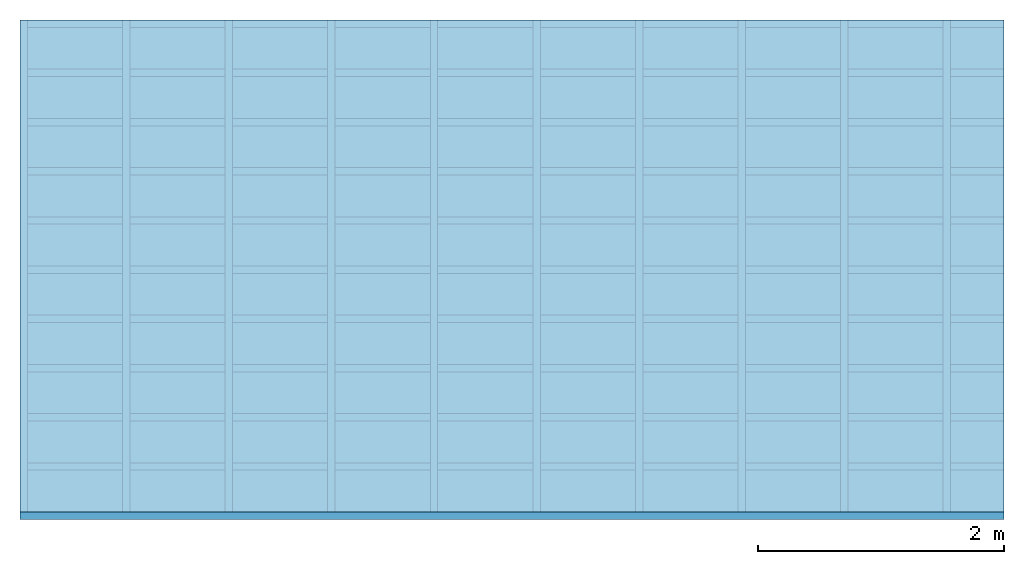
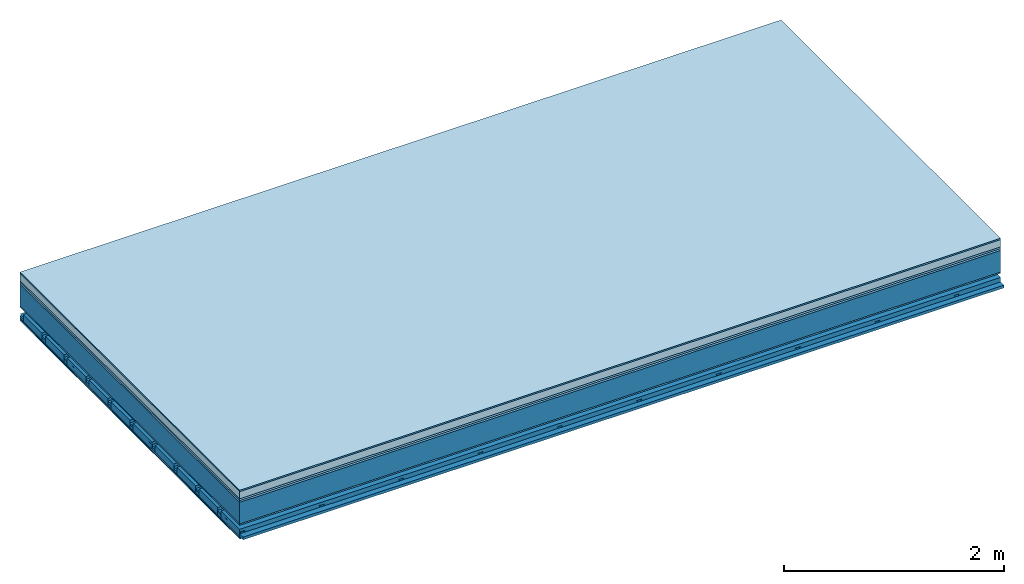
# One storey: 8 plates, 4 members, 1 element without a shape of its own.
"""IFC4 building model written with IfcOpenShell, lengths in metres."""

import ifcopenshell
import ifcopenshell.guid

model = None  # the IFC model being written
_history = None  # IfcOwnerHistory: only IFC2X3 demands one
_inside = {}  # id of a spatial element -> (the spatial element, [elements in it])
_under = {}  # id of a project, library or spatial element -> (it, [spatial elements below it])
_declared = {}  # id of a project -> (the project, [libraries it declares])
_typed = {}  # id of a type object -> (the type object, [elements of that type])
_made_of = {}  # id of a material, layer set ... -> (it, [elements and type objects made of it])


def new_model(schema):
    """Start an empty IFC model of exactly this schema.

    Asked for "IFC4X3", IfcOpenShell would pick the latest addendum, in which some entities
    have other attributes; the version numbers below select the first issue.
    IFC2X3 requires an IfcOwnerHistory on every rooted entity: one is made here for all.
    """
    global model, _history
    if schema == "IFC4X3":
        model = ifcopenshell.file(schema_version=(4, 3, 0, 0))
    else:
        model = ifcopenshell.file(schema=schema)
    _inside.clear()
    _under.clear()
    _declared.clear()
    _typed.clear()
    _made_of.clear()
    _history = None
    if model.schema == "IFC2X3":
        org = make("IfcOrganization", Name="unknown")
        user = make(
            "IfcPersonAndOrganization",
            ThePerson=make("IfcPerson", FamilyName="unknown"),
            TheOrganization=org,
        )
        app = make(
            "IfcApplication",
            ApplicationDeveloper=org,
            Version="unknown",
            ApplicationFullName="unknown",
            ApplicationIdentifier="unknown",
        )
        _history = make(
            "IfcOwnerHistory",
            OwningUser=user,
            OwningApplication=app,
            ChangeAction="ADDED",
            CreationDate=0,
        )
    return model


def make(cls, **values):
    """One entity of the class cls with the attributes given. An attribute that is None is left unset."""
    return model.create_entity(
        cls, **{name: value for name, value in values.items() if value is not None}
    )


def rooted(cls, **values):
    """An entity with a GlobalId (a new one), such as an element, a storey or a relation."""
    return make(cls, GlobalId=ifcopenshell.guid.new(), OwnerHistory=_history, **values)


def si_unit(unit_type, name, prefix=None):
    """IfcSIUnit, for example si_unit("LENGTHUNIT", "METRE", prefix="MILLI")."""
    return make("IfcSIUnit", UnitType=unit_type, Prefix=prefix, Name=name)


def derived_unit(unit_type, elements):
    """IfcDerivedUnit: a product of units, each with its exponent."""
    return make(
        "IfcDerivedUnit",
        Elements=[
            make("IfcDerivedUnitElement", Unit=unit, Exponent=power)
            for unit, power in elements
        ],
        UnitType=unit_type,
    )


def assignment(units):
    """IfcUnitAssignment: the units of a project."""
    return None if units is None else make("IfcUnitAssignment", Units=units)


def point(xyz):
    """IfcCartesianPoint."""
    return None if xyz is None else make("IfcCartesianPoint", Coordinates=xyz)


def direction(xyz):
    """IfcDirection."""
    return None if xyz is None else make("IfcDirection", DirectionRatios=xyz)


def frame(location, z_axis=None, x_axis=None):
    """IfcAxis2Placement3D, a coordinate frame: its origin and axes. An axis left out is left unset."""
    return make(
        "IfcAxis2Placement3D",
        Location=point(location),
        Axis=direction(z_axis),
        RefDirection=direction(x_axis),
    )


def frame_2d(location, x_axis=None):
    """IfcAxis2Placement2D, a coordinate frame in the plane: its origin and x axis."""
    return make(
        "IfcAxis2Placement2D", Location=point(location), RefDirection=direction(x_axis)
    )


def origin():
    """The frame at (0, 0, 0) with its axes left unset."""
    return frame((0.0, 0.0, 0.0))


def origin_with_axes():
    """The frame at (0, 0, 0) with the z axis (0, 0, 1) and the x axis (1, 0, 0) written out."""
    return frame((0.0, 0.0, 0.0), z_axis=(0.0, 0.0, 1.0), x_axis=(1.0, 0.0, 0.0))


def place(relative_to, where):
    """IfcLocalPlacement: puts the frame where relative to a parent placement (None: the world)."""
    return make(
        "IfcLocalPlacement", PlacementRelTo=relative_to, RelativePlacement=where
    )


def context(
    kind, dimensions, precision=None, world=None, true_north=None, identifier=None
):
    """IfcGeometricRepresentationContext, for example the 3D "Model" context."""
    return make(
        "IfcGeometricRepresentationContext",
        ContextIdentifier=identifier,
        ContextType=kind,
        CoordinateSpaceDimension=dimensions,
        Precision=precision,
        WorldCoordinateSystem=world,
        TrueNorth=true_north,
    )


def project(units=None, contexts=None):
    """IfcProject with its units and contexts."""
    return rooted(
        "IfcProject",
        Name="project",
        RepresentationContexts=contexts,
        UnitsInContext=assignment(units),
    )


def spatial(cls, under=None, at=None, **own):
    """A site, building, storey or space (cls), placed at a placement, below another one or the project."""
    s = rooted(cls, ObjectPlacement=at, **own)
    if under is not None:
        _under.setdefault(under.id(), (under, []))[1].append(s)
    return s


def polyline(points):
    """IfcPolyline through the points."""
    return make("IfcPolyline", Points=[point(p) for p in points])


def profile(cls, at=None, kind="AREA", **sizes):
    """A parametric profile (cls). Its sizes go by their IFC names, for example OverallWidth=200.0."""
    return make(cls, ProfileType=kind, Position=at, **sizes)


def rectangle(**sizes):
    """IfcRectangleProfileDef."""
    return profile("IfcRectangleProfileDef", **sizes)


def outline(outer, holes=None, kind="AREA"):
    """IfcArbitraryClosedProfileDef: a profile drawn as a closed curve; with holes, ...WithVoids."""
    if holes is None:
        return make("IfcArbitraryClosedProfileDef", ProfileType=kind, OuterCurve=outer)
    return make(
        "IfcArbitraryProfileDefWithVoids",
        ProfileType=kind,
        OuterCurve=outer,
        InnerCurves=holes,
    )


def extrude(swept, where, along, depth):
    """IfcExtrudedAreaSolid: the profile swept, set in the frame where, extruded along a direction by depth."""
    return make(
        "IfcExtrudedAreaSolid",
        SweptArea=swept,
        Position=where,
        ExtrudedDirection=direction(along),
        Depth=depth,
    )


def shape(context_of_items, identifier, shape_type, items):
    """IfcShapeRepresentation: the items that make up one representation, for example the "Body"."""
    return make(
        "IfcShapeRepresentation",
        ContextOfItems=context_of_items,
        RepresentationIdentifier=identifier,
        RepresentationType=shape_type,
        Items=items,
    )


def material(Name=None, Category=None):
    """IfcMaterial."""
    return make("IfcMaterial", Name=Name, Category=Category)


def layer(
    of_material, thickness, ventilated=None, Name=None, Category=None, Priority=None
):
    """IfcMaterialLayer: one layer of a wall or slab, of a material (None: an air gap)."""
    return make(
        "IfcMaterialLayer",
        Material=of_material,
        LayerThickness=thickness,
        IsVentilated=ventilated,
        Name=Name,
        Category=Category,
        Priority=Priority,
    )


def layer_set(layers, Name=None):
    """IfcMaterialLayerSet."""
    return make("IfcMaterialLayerSet", MaterialLayers=layers, LayerSetName=Name)


def made_of(thing, what):
    """Note that an element or type object is made of a material, layer set ...; save() writes the relation."""
    if what is not None:
        _made_of.setdefault(what.id(), (what, []))[1].append(thing)
    return thing


def type_object(cls, material=None, **own):
    """A type object (cls), such as IfcWallType, which elements share."""
    return made_of(rooted(cls, **own), material)


def element(
    cls,
    number,
    at=None,
    inside=None,
    cuts=None,
    type_object=None,
    material=None,
    context=None,
    identifier="Body",
    shape_type=None,
    held_by="IfcProductDefinitionShape",
    body=None,
    shapes=None,
    **own,
):
    """One element of the class cls, such as IfcWall. Its Tag is "e" and its number.

    at: its placement. inside: the storey or other place that contains it. cuts: it is an
    opening in that element (IfcRelVoidsElement). A single representation is given by context,
    identifier, shape_type and body (its items); several are given by shapes. held_by: the class
    of the entity that holds the representations. save() writes the other relations.
    """
    e = rooted(cls, Tag="e%d" % number, ObjectPlacement=at, **own)
    if body is not None:
        shapes = [shape(context, identifier, shape_type, body)]
    if shapes is not None:
        e.Representation = make(held_by, Representations=shapes)
    if inside is not None:
        _inside.setdefault(inside.id(), (inside, []))[1].append(e)
    if cuts is not None:
        rooted(
            "IfcRelVoidsElement", RelatingBuildingElement=cuts, RelatedOpeningElement=e
        )
    if type_object is not None:
        _typed.setdefault(type_object.id(), (type_object, []))[1].append(e)
    return made_of(e, material)


def aggregate(whole, parts):
    """IfcRelAggregates: a whole, such as a stair, and the parts it consists of."""
    return rooted("IfcRelAggregates", RelatingObject=whole, RelatedObjects=parts)


def save(model, path):
    """Write the relations noted so far, then the file.

    IfcRelAggregates (storeys below a building ...), IfcRelContainedInSpatialStructure (elements
    in a storey), IfcRelDefinesByType, IfcRelAssociatesMaterial and IfcRelDeclares: one each for
    every whole, place, type object, material and project.
    """
    for whole, parts in _under.values():
        aggregate(whole, parts)
    for where, things in _inside.values():
        rooted(
            "IfcRelContainedInSpatialStructure",
            RelatedElements=things,
            RelatingStructure=where,
        )
    for kind, things in _typed.values():
        rooted("IfcRelDefinesByType", RelatedObjects=things, RelatingType=kind)
    for what, things in _made_of.values():
        rooted("IfcRelAssociatesMaterial", RelatedObjects=things, RelatingMaterial=what)
    for by, libraries in _declared.values():
        rooted("IfcRelDeclares", RelatingContext=by, RelatedDefinitions=libraries)
    model.write(path)


model = new_model("IFC4")

# Units and contexts
plan_context = context("Plan", 3, precision=1e-05, world=origin(), true_north=direction((0.0, 1.0)))
model_context = context("Model", 3, precision=1e-05, world=origin(), true_north=direction((0.0, 1.0)))
ifc_project = project(units=[si_unit("LENGTHUNIT", "METRE"), derived_unit("SOUNDPRESSUREUNIT", [(si_unit("PRESSUREUNIT", "PASCAL", prefix="MICRO"), 0)]), si_unit("ENERGYUNIT", "JOULE", prefix="MEGA"), si_unit("MASSUNIT", "GRAM", prefix="KILO"), derived_unit("THERMALTRANSMITTANCEUNIT", [(si_unit("POWERUNIT", "WATT"), 1), (si_unit("AREAUNIT", "SQUARE_METRE"), -1), (si_unit("THERMODYNAMICTEMPERATUREUNIT", "KELVIN"), -1)]), derived_unit("AREADENSITYUNIT", [(si_unit("MASSUNIT", "GRAM", prefix="KILO"), 1), (si_unit("AREAUNIT", "SQUARE_METRE"), -1)]), derived_unit("USERDEFINED", [(si_unit("ENERGYUNIT", "JOULE", prefix="MEGA"), 1), (si_unit("AREAUNIT", "SQUARE_METRE"), -1)])], contexts=[plan_context, model_context])

# Site, building, storey
site = spatial("IfcSite", under=ifc_project)
building_placement = place(None, origin())
building = spatial("IfcBuilding", under=site, at=building_placement)
storey_placement = place(building_placement, origin())
storey = spatial("IfcBuildingStorey", under=building, at=storey_placement)

# Slab, members, plates
ifc_material_1 = material(Category="11.013")
ifc_layer_1 = layer(ifc_material_1, 0.015, Name="Flooring")
ifc_material_2 = material(Name="Cement screed", Category="04.006")
ifc_layer_2 = layer(ifc_material_2, 0.08, Name="On-material")
ifc_material_3 = material(Name="Wood fiber generic product", Category="10.009")
ifc_layer_3 = layer(ifc_material_3, 0.02, Name="Impact sound insulation")
ifc_material_4 = material(Category="10.004")
ifc_layer_4 = layer(ifc_material_4, 0.02, Name="Additional insulation")
ifc_material_5 = material(Name="no composite action")
ifc_layer_5 = layer(ifc_material_5, 0.0, Name="Bond")
ifc_layer_6 = layer(None, 0.24, Name="Supporting structure")
ifc_material_6 = material(Name="of the art")
ifc_layer_7 = layer(ifc_material_6, 0.0, Name="Bond")
ifc_material_7 = material(Category="03.007")
ifc_layer_8 = layer(ifc_material_7, 0.015, Name="Lower layer 1")
ifc_layer_9 = layer(None, 0.095, Name="Coupling")
ifc_layer_10 = layer(None, 0.03, Name="Battens / profiles")
ifc_material_8 = material(Name="Plasterboard type A", Category="03.008")
ifc_layer_11 = layer(ifc_material_8, 0.0125, Name="Ceiling covering 1st layer")
ifc_layer_12 = layer(ifc_material_8, 0.0125, Name="Ceiling covering layer 2")
ifc_material_9 = material(Category="04.001")
ifc_layer_13 = layer(ifc_material_9, 0.003, Name="Surface / treatment")
ifc_layer_set = layer_set([ifc_layer_1, ifc_layer_2, ifc_layer_3, ifc_layer_4, ifc_layer_5, ifc_layer_6, ifc_layer_7, ifc_layer_8, ifc_layer_9, ifc_layer_10, ifc_layer_11, ifc_layer_12, ifc_layer_13])
slab_type = type_object("IfcSlabType", Name="A2165", PredefinedType="NOTDEFINED", material=ifc_layer_set)
slab_placement = place(None, frame((0.0, 0.0, 0.0), z_axis=(0.0, 0.0, -1.0), x_axis=(1.0, 0.0, 0.0)))
slab = element("IfcSlab", 1, at=slab_placement, inside=storey, type_object=slab_type, material=ifc_layer_set, Name="Slab #1")
ifc_material_10 = material(Name="Solid timber panel")
member_1_placement = place(slab_placement, origin())
member_1 = element("IfcMember", 2, at=member_1_placement, material=ifc_material_10, Name="Supporting structure", context=plan_context, shape_type="SweptSolid", body=[
    extrude(rectangle(XDim=1.0, YDim=0.24, at=frame_2d((0.5, 0.12), x_axis=(1.0, 0.0))), frame((0.0, 4.0, 0.135), z_axis=(0.0, -1.0, 0.0), x_axis=(1.0, 0.0, 0.0)), (0.0, 0.0, 1.0), 4.0),
    extrude(rectangle(XDim=1.0, YDim=0.24, at=frame_2d((0.5, 0.12), x_axis=(1.0, 0.0))), frame((1.0, 4.0, 0.135), z_axis=(0.0, -1.0, 0.0), x_axis=(1.0, 0.0, 0.0)), (0.0, 0.0, 1.0), 4.0),
    extrude(rectangle(XDim=1.0, YDim=0.24, at=frame_2d((0.5, 0.12), x_axis=(1.0, 0.0))), frame((2.0, 4.0, 0.135), z_axis=(0.0, -1.0, 0.0), x_axis=(1.0, 0.0, 0.0)), (0.0, 0.0, 1.0), 4.0),
    extrude(rectangle(XDim=1.0, YDim=0.24, at=frame_2d((0.5, 0.12), x_axis=(1.0, 0.0))), frame((3.0, 4.0, 0.135), z_axis=(0.0, -1.0, 0.0), x_axis=(1.0, 0.0, 0.0)), (0.0, 0.0, 1.0), 4.0),
    extrude(rectangle(XDim=1.0, YDim=0.24, at=frame_2d((0.5, 0.12), x_axis=(1.0, 0.0))), frame((4.0, 4.0, 0.135), z_axis=(0.0, -1.0, 0.0), x_axis=(1.0, 0.0, 0.0)), (0.0, 0.0, 1.0), 4.0),
    extrude(rectangle(XDim=1.0, YDim=0.24, at=frame_2d((0.5, 0.12), x_axis=(1.0, 0.0))), frame((5.0, 4.0, 0.135), z_axis=(0.0, -1.0, 0.0), x_axis=(1.0, 0.0, 0.0)), (0.0, 0.0, 1.0), 4.0),
    extrude(rectangle(XDim=1.0, YDim=0.24, at=frame_2d((0.5, 0.12), x_axis=(1.0, 0.0))), frame((6.0, 4.0, 0.135), z_axis=(0.0, -1.0, 0.0), x_axis=(1.0, 0.0, 0.0)), (0.0, 0.0, 1.0), 4.0),
    extrude(rectangle(XDim=1.0, YDim=0.24, at=frame_2d((0.5, 0.12), x_axis=(1.0, 0.0))), frame((7.0, 4.0, 0.135), z_axis=(0.0, -1.0, 0.0), x_axis=(1.0, 0.0, 0.0)), (0.0, 0.0, 1.0), 4.0),
])
ifc_material_11 = material()
member_2_placement = place(slab_placement, origin())
member_2 = element("IfcMember", 3, at=member_2_placement, material=ifc_material_11, Name="Coupling", context=plan_context, shape_type="SweptSolid", body=[
    extrude(outline(polyline([(0.0, 0.0), (0.06, 0.0), (0.04, 0.02), (0.02, 0.02), (0.0, 0.0)])), frame((0.0, 4.0, 0.465), z_axis=(0.0, -1.0, 0.0), x_axis=(1.0, 0.0, 0.0)), (0.0, 0.0, 1.0), 4.0),
    extrude(outline(polyline([(0.0, 0.0), (0.06, 0.0), (0.04, 0.02), (0.02, 0.02), (0.0, 0.0)])), frame((0.834, 4.0, 0.465), z_axis=(0.0, -1.0, 0.0), x_axis=(1.0, 0.0, 0.0)), (0.0, 0.0, 1.0), 4.0),
    extrude(outline(polyline([(0.0, 0.0), (0.06, 0.0), (0.04, 0.02), (0.02, 0.02), (0.0, 0.0)])), frame((1.668, 4.0, 0.465), z_axis=(0.0, -1.0, 0.0), x_axis=(1.0, 0.0, 0.0)), (0.0, 0.0, 1.0), 4.0),
    extrude(outline(polyline([(0.0, 0.0), (0.06, 0.0), (0.04, 0.02), (0.02, 0.02), (0.0, 0.0)])), frame((2.502, 4.0, 0.465), z_axis=(0.0, -1.0, 0.0), x_axis=(1.0, 0.0, 0.0)), (0.0, 0.0, 1.0), 4.0),
    extrude(outline(polyline([(0.0, 0.0), (0.06, 0.0), (0.04, 0.02), (0.02, 0.02), (0.0, 0.0)])), frame((3.336, 4.0, 0.465), z_axis=(0.0, -1.0, 0.0), x_axis=(1.0, 0.0, 0.0)), (0.0, 0.0, 1.0), 4.0),
    extrude(outline(polyline([(0.0, 0.0), (0.06, 0.0), (0.04, 0.02), (0.02, 0.02), (0.0, 0.0)])), frame((4.17, 4.0, 0.465), z_axis=(0.0, -1.0, 0.0), x_axis=(1.0, 0.0, 0.0)), (0.0, 0.0, 1.0), 4.0),
    extrude(outline(polyline([(0.0, 0.0), (0.06, 0.0), (0.04, 0.02), (0.02, 0.02), (0.0, 0.0)])), frame((5.004, 4.0, 0.465), z_axis=(0.0, -1.0, 0.0), x_axis=(1.0, 0.0, 0.0)), (0.0, 0.0, 1.0), 4.0),
    extrude(outline(polyline([(0.0, 0.0), (0.06, 0.0), (0.04, 0.02), (0.02, 0.02), (0.0, 0.0)])), frame((5.838, 4.0, 0.465), z_axis=(0.0, -1.0, 0.0), x_axis=(1.0, 0.0, 0.0)), (0.0, 0.0, 1.0), 4.0),
    extrude(outline(polyline([(0.0, 0.0), (0.06, 0.0), (0.04, 0.02), (0.02, 0.02), (0.0, 0.0)])), frame((6.672, 4.0, 0.465), z_axis=(0.0, -1.0, 0.0), x_axis=(1.0, 0.0, 0.0)), (0.0, 0.0, 1.0), 4.0),
    extrude(outline(polyline([(0.0, 0.0), (0.06, 0.0), (0.04, 0.02), (0.02, 0.02), (0.0, 0.0)])), frame((7.506, 4.0, 0.465), z_axis=(0.0, -1.0, 0.0), x_axis=(1.0, 0.0, 0.0)), (0.0, 0.0, 1.0), 4.0),
])
member_3_placement = place(slab_placement, origin())
member_3 = element("IfcMember", 4, at=member_3_placement, material=ifc_material_11, Name="Battens / profiles", context=plan_context, shape_type="SweptSolid", body=[
    extrude(rectangle(XDim=0.06, YDim=0.03, at=frame_2d((0.03, 0.015), x_axis=(1.0, 0.0))), frame((0.0, 0.0, 0.485), z_axis=(1.0, 0.0, 0.0), x_axis=(0.0, 1.0, 0.0)), (0.0, 0.0, 1.0), 8.0),
    extrude(rectangle(XDim=0.06, YDim=0.03, at=frame_2d((0.03, 0.015), x_axis=(1.0, 0.0))), frame((0.0, 0.4, 0.485), z_axis=(1.0, 0.0, 0.0), x_axis=(0.0, 1.0, 0.0)), (0.0, 0.0, 1.0), 8.0),
    extrude(rectangle(XDim=0.06, YDim=0.03, at=frame_2d((0.03, 0.015), x_axis=(1.0, 0.0))), frame((0.0, 0.8, 0.485), z_axis=(1.0, 0.0, 0.0), x_axis=(0.0, 1.0, 0.0)), (0.0, 0.0, 1.0), 8.0),
    extrude(rectangle(XDim=0.06, YDim=0.03, at=frame_2d((0.03, 0.015), x_axis=(1.0, 0.0))), frame((0.0, 1.2, 0.485), z_axis=(1.0, 0.0, 0.0), x_axis=(0.0, 1.0, 0.0)), (0.0, 0.0, 1.0), 8.0),
    extrude(rectangle(XDim=0.06, YDim=0.03, at=frame_2d((0.03, 0.015), x_axis=(1.0, 0.0))), frame((0.0, 1.6, 0.485), z_axis=(1.0, 0.0, 0.0), x_axis=(0.0, 1.0, 0.0)), (0.0, 0.0, 1.0), 8.0),
    extrude(rectangle(XDim=0.06, YDim=0.03, at=frame_2d((0.03, 0.015), x_axis=(1.0, 0.0))), frame((0.0, 2.0, 0.485), z_axis=(1.0, 0.0, 0.0), x_axis=(0.0, 1.0, 0.0)), (0.0, 0.0, 1.0), 8.0),
    extrude(rectangle(XDim=0.06, YDim=0.03, at=frame_2d((0.03, 0.015), x_axis=(1.0, 0.0))), frame((0.0, 2.4, 0.485), z_axis=(1.0, 0.0, 0.0), x_axis=(0.0, 1.0, 0.0)), (0.0, 0.0, 1.0), 8.0),
    extrude(rectangle(XDim=0.06, YDim=0.03, at=frame_2d((0.03, 0.015), x_axis=(1.0, 0.0))), frame((0.0, 2.8, 0.485), z_axis=(1.0, 0.0, 0.0), x_axis=(0.0, 1.0, 0.0)), (0.0, 0.0, 1.0), 8.0),
    extrude(rectangle(XDim=0.06, YDim=0.03, at=frame_2d((0.03, 0.015), x_axis=(1.0, 0.0))), frame((0.0, 3.2, 0.485), z_axis=(1.0, 0.0, 0.0), x_axis=(0.0, 1.0, 0.0)), (0.0, 0.0, 1.0), 8.0),
    extrude(rectangle(XDim=0.06, YDim=0.03, at=frame_2d((0.03, 0.015), x_axis=(1.0, 0.0))), frame((0.0, 3.6, 0.485), z_axis=(1.0, 0.0, 0.0), x_axis=(0.0, 1.0, 0.0)), (0.0, 0.0, 1.0), 8.0),
    extrude(rectangle(XDim=0.06, YDim=0.03, at=frame_2d((0.03, 0.015), x_axis=(1.0, 0.0))), frame((0.0, 4.0, 0.485), z_axis=(1.0, 0.0, 0.0), x_axis=(0.0, 1.0, 0.0)), (0.0, 0.0, 1.0), 8.0),
])
ifc_material_12 = material()
member_4_placement = place(slab_placement, origin())
member_4 = element("IfcMember", 5, at=member_4_placement, material=ifc_material_12, Name="Cavity", context=plan_context, shape_type="SweptSolid", body=[
    extrude(rectangle(XDim=0.34, YDim=0.08, at=frame_2d((0.17, 0.04), x_axis=(1.0, 0.0))), frame((0.0, 0.06, 0.435), z_axis=(1.0, 0.0, 0.0), x_axis=(0.0, 1.0, 0.0)), (0.0, 0.0, 1.0), 8.0),
    extrude(rectangle(XDim=0.34, YDim=0.08, at=frame_2d((0.17, 0.04), x_axis=(1.0, 0.0))), frame((0.0, 0.46, 0.435), z_axis=(1.0, 0.0, 0.0), x_axis=(0.0, 1.0, 0.0)), (0.0, 0.0, 1.0), 8.0),
    extrude(rectangle(XDim=0.34, YDim=0.08, at=frame_2d((0.17, 0.04), x_axis=(1.0, 0.0))), frame((0.0, 0.86, 0.435), z_axis=(1.0, 0.0, 0.0), x_axis=(0.0, 1.0, 0.0)), (0.0, 0.0, 1.0), 8.0),
    extrude(rectangle(XDim=0.34, YDim=0.08, at=frame_2d((0.17, 0.04), x_axis=(1.0, 0.0))), frame((0.0, 1.26, 0.435), z_axis=(1.0, 0.0, 0.0), x_axis=(0.0, 1.0, 0.0)), (0.0, 0.0, 1.0), 8.0),
    extrude(rectangle(XDim=0.34, YDim=0.08, at=frame_2d((0.17, 0.04), x_axis=(1.0, 0.0))), frame((0.0, 1.66, 0.435), z_axis=(1.0, 0.0, 0.0), x_axis=(0.0, 1.0, 0.0)), (0.0, 0.0, 1.0), 8.0),
    extrude(rectangle(XDim=0.34, YDim=0.08, at=frame_2d((0.17, 0.04), x_axis=(1.0, 0.0))), frame((0.0, 2.06, 0.435), z_axis=(1.0, 0.0, 0.0), x_axis=(0.0, 1.0, 0.0)), (0.0, 0.0, 1.0), 8.0),
    extrude(rectangle(XDim=0.34, YDim=0.08, at=frame_2d((0.17, 0.04), x_axis=(1.0, 0.0))), frame((0.0, 2.46, 0.435), z_axis=(1.0, 0.0, 0.0), x_axis=(0.0, 1.0, 0.0)), (0.0, 0.0, 1.0), 8.0),
    extrude(rectangle(XDim=0.34, YDim=0.08, at=frame_2d((0.17, 0.04), x_axis=(1.0, 0.0))), frame((0.0, 2.86, 0.435), z_axis=(1.0, 0.0, 0.0), x_axis=(0.0, 1.0, 0.0)), (0.0, 0.0, 1.0), 8.0),
    extrude(rectangle(XDim=0.34, YDim=0.08, at=frame_2d((0.17, 0.04), x_axis=(1.0, 0.0))), frame((0.0, 3.26, 0.435), z_axis=(1.0, 0.0, 0.0), x_axis=(0.0, 1.0, 0.0)), (0.0, 0.0, 1.0), 8.0),
    extrude(rectangle(XDim=0.34, YDim=0.08, at=frame_2d((0.17, 0.04), x_axis=(1.0, 0.0))), frame((0.0, 3.66, 0.435), z_axis=(1.0, 0.0, 0.0), x_axis=(0.0, 1.0, 0.0)), (0.0, 0.0, 1.0), 8.0),
])
plate_1_placement = place(slab_placement, origin())
plate_1 = element("IfcPlate", 6, at=plate_1_placement, material=ifc_material_1, Name="Flooring", context=plan_context, shape_type="SweptSolid", body=[
    extrude(rectangle(XDim=8.0, YDim=4.0, at=frame_2d((4.0, 2.0), x_axis=(1.0, 0.0))), origin_with_axes(), (0.0, 0.0, 1.0), 0.015),
])
plate_2_placement = place(slab_placement, origin())
plate_2 = element("IfcPlate", 7, at=plate_2_placement, material=ifc_material_2, Name="On-material", context=plan_context, shape_type="SweptSolid", body=[
    extrude(rectangle(XDim=8.0, YDim=4.0, at=frame_2d((4.0, 2.0), x_axis=(1.0, 0.0))), frame((0.0, 0.0, 0.015), z_axis=(0.0, 0.0, 1.0), x_axis=(1.0, 0.0, 0.0)), (0.0, 0.0, 1.0), 0.08),
])
plate_3_placement = place(slab_placement, origin())
plate_3 = element("IfcPlate", 8, at=plate_3_placement, material=ifc_material_3, Name="Impact sound insulation", context=plan_context, shape_type="SweptSolid", body=[
    extrude(rectangle(XDim=8.0, YDim=4.0, at=frame_2d((4.0, 2.0), x_axis=(1.0, 0.0))), frame((0.0, 0.0, 0.095), z_axis=(0.0, 0.0, 1.0), x_axis=(1.0, 0.0, 0.0)), (0.0, 0.0, 1.0), 0.02),
])
plate_4_placement = place(slab_placement, origin())
plate_4 = element("IfcPlate", 9, at=plate_4_placement, material=ifc_material_4, Name="Additional insulation", context=plan_context, shape_type="SweptSolid", body=[
    extrude(rectangle(XDim=8.0, YDim=4.0, at=frame_2d((4.0, 2.0), x_axis=(1.0, 0.0))), frame((0.0, 0.0, 0.115), z_axis=(0.0, 0.0, 1.0), x_axis=(1.0, 0.0, 0.0)), (0.0, 0.0, 1.0), 0.02),
])
plate_5_placement = place(slab_placement, origin())
plate_5 = element("IfcPlate", 10, at=plate_5_placement, material=ifc_material_7, Name="Lower layer 1", context=plan_context, shape_type="SweptSolid", body=[
    extrude(rectangle(XDim=8.0, YDim=4.0, at=frame_2d((4.0, 2.0), x_axis=(1.0, 0.0))), frame((0.0, 0.0, 0.375), z_axis=(0.0, 0.0, 1.0), x_axis=(1.0, 0.0, 0.0)), (0.0, 0.0, 1.0), 0.015),
])
plate_6_placement = place(slab_placement, origin())
plate_6 = element("IfcPlate", 11, at=plate_6_placement, material=ifc_material_8, Name="Ceiling covering 1st layer", context=plan_context, shape_type="SweptSolid", body=[
    extrude(rectangle(XDim=8.0, YDim=4.0, at=frame_2d((4.0, 2.0), x_axis=(1.0, 0.0))), frame((0.0, 0.0, 0.515), z_axis=(0.0, 0.0, 1.0), x_axis=(1.0, 0.0, 0.0)), (0.0, 0.0, 1.0), 0.0125),
])
plate_7_placement = place(slab_placement, origin())
plate_7 = element("IfcPlate", 12, at=plate_7_placement, material=ifc_material_8, Name="Ceiling covering layer 2", context=plan_context, shape_type="SweptSolid", body=[
    extrude(rectangle(XDim=8.0, YDim=4.0, at=frame_2d((4.0, 2.0), x_axis=(1.0, 0.0))), frame((0.0, 0.0, 0.5275), z_axis=(0.0, 0.0, 1.0), x_axis=(1.0, 0.0, 0.0)), (0.0, 0.0, 1.0), 0.0125),
])
plate_8_placement = place(slab_placement, origin())
plate_8 = element("IfcPlate", 13, at=plate_8_placement, material=ifc_material_9, Name="Surface / treatment", context=plan_context, shape_type="SweptSolid", body=[
    extrude(rectangle(XDim=8.0, YDim=4.0, at=frame_2d((4.0, 2.0), x_axis=(1.0, 0.0))), frame((0.0, 0.0, 0.54), z_axis=(0.0, 0.0, 1.0), x_axis=(1.0, 0.0, 0.0)), (0.0, 0.0, 1.0), 0.003),
])
aggregate(slab, [plate_1, plate_2, plate_3, plate_4, member_1, plate_5, member_2, member_3, member_4, plate_6, plate_7, plate_8])

save(model, "model.ifc")
